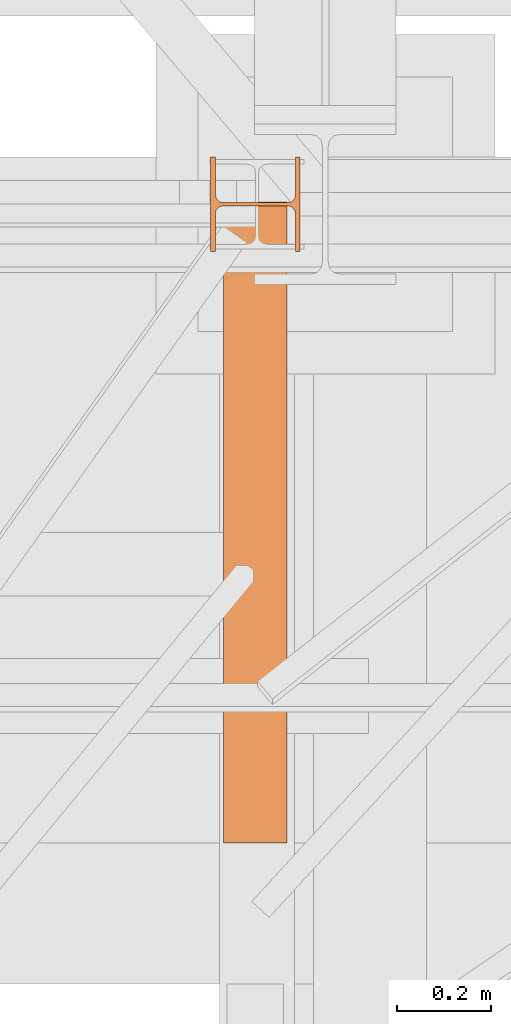
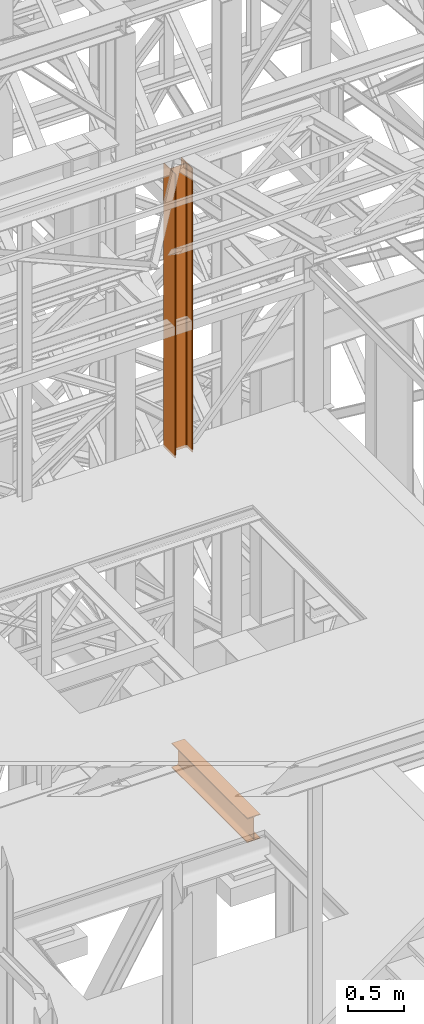
# One storey, part 75 of 208: 2 proxies.
"""IFC2X3 building model written with IfcOpenShell, lengths in millimetres."""

from ifc_helpers import new_model, entity, si_unit, converted_unit, frame, origin, origin_with_axes, place, context, subcontext, project, spatial, faceted_brep, element, save


model = new_model("IFC2X3")

# Units and contexts
model_context = context("Model", 3, precision=1e-05, world=origin())
plan_context = context("Plan", 3, precision=1e-05, world=origin())
body_context = subcontext(model_context, "Body", "Model", "MODEL_VIEW")
ifc_project = project(units=[si_unit("LENGTHUNIT", "METRE", prefix="MILLI"), converted_unit("PLANEANGLEUNIT", "DEGREE", entity("IfcPlaneAngleMeasure", 0.0174532925199433), si_unit("PLANEANGLEUNIT", "RADIAN"), dimensions=[0, 0, 0, 0, 0, 0, 0]), si_unit("AREAUNIT", "SQUARE_METRE"), si_unit("VOLUMEUNIT", "CUBIC_METRE")], contexts=[model_context, plan_context])

# Building, storey
building_placement = place(None, origin())
building = spatial("IfcBuilding", under=ifc_project, at=building_placement, CompositionType="COMPLEX")
storey_placement = place(building_placement, origin_with_axes())
storey = spatial("IfcBuildingStorey", under=building, at=storey_placement, Name="Geschoss", CompositionType="ELEMENT")

# Proxies
proxy_1_placement = place(storey_placement, frame((5249.965071036444, -17362.574391808, 8484.990002086157), z_axis=(0.0, 0.0, 1.0), x_axis=(1.0, 0.0, 0.0)))
element("IfcBuildingElementProxy", 1, at=proxy_1_placement, inside=storey, context=body_context, shape_type="Brep", body=[
    faceted_brep([(190.0100211920199, 0.00999999999839929, 3115.0099922514), (180.0100232781824, 0.00999999999839929, 3115.0099922514), (180.0100158276018, 78.75999940395195, 3115.0099922514), (178.1454707803187, 88.07581143289644, 3115.0099922514), (171.3258277000841, 94.89545311614711, 3115.0099922514), (162.0100166024622, 96.7600014230593, 3115.0099922514), (28.0100058140215, 96.7600014230593, 3115.0099922514), (18.69419471639958, 94.89545311614711, 3115.0099922514), (11.87455163616505, 88.07581143289644, 3115.0099922514), (10.01000658888188, 78.75999940395195, 3115.0099922514), (10.01000658888188, 0.00999999999839929, 3115.0099922514), (0.01000867504444614, 0.00999999999839929, 3115.0099922514), (0.01000867504444614, 200.0100029802306, 3115.0099922514), (10.01000658888188, 200.0100029802306, 3115.0099922514), (10.01000658888188, 121.2600035762771, 3115.0099922514), (11.87455163616505, 111.9441915473326, 3115.0099922514), (18.69419471639958, 105.1245498640819, 3115.0099922514), (28.0100058140215, 103.2600015571697, 3115.0099922514), (162.0100166024622, 103.2600015571697, 3115.0099922514), (171.3258277000841, 105.1245498640819, 3115.0099922514), (178.1454707803187, 111.9441915473326, 3115.0099922514), (180.0100158276018, 121.2600035762771, 3115.0099922514), (180.0100232781824, 200.0100029802306, 3115.0099922514), (190.0100211920199, 200.0100029802306, 3115.0099922514), (190.0100211920199, 200.0100029802306, 3115.0099922514), (190.0100125169756, 200.0100029802306, 0.00999999999839929), (190.0100125169756, 0.00999999999839929, 0.00999999999839929), (190.0100211920199, 0.00999999999839929, 3115.0099922514), (180.0100232781824, 200.0100029802306, 3115.0099922514), (180.0100146031382, 200.0100029802306, 0.00999999999839929), (190.0100125169756, 200.0100029802306, 0.00999999999839929), (190.0100211920199, 200.0100029802306, 3115.0099922514), (180.0100158276018, 121.2600035762771, 3115.0099922514), (180.0100071525576, 121.2600035762771, 0.00999999999839929), (180.0100146031382, 200.0100029802306, 0.00999999999839929), (180.0100232781824, 200.0100029802306, 3115.0099922514), (178.1454707803187, 111.9441915473326, 3115.0099922514), (178.1454621052744, 111.9441915473326, 0.00999999999839929), (180.0100071525576, 121.2600035762771, 0.00999999999839929), (180.0100158276018, 121.2600035762771, 3115.0099922514), (171.3258277000841, 105.1245498640819, 3115.0099922514), (171.3258190250399, 105.1245498640819, 0.00999999999839929), (178.1454621052744, 111.9441915473326, 0.00999999999839929), (178.1454707803187, 111.9441915473326, 3115.0099922514), (162.0100166024622, 103.2600015571697, 3115.0099922514), (162.010007927418, 103.2600015571697, 0.00999999999839929), (171.3258190250399, 105.1245498640819, 0.00999999999839929), (171.3258277000841, 105.1245498640819, 3115.0099922514), (28.0100058140215, 103.2600015571697, 3115.0099922514), (28.00999713897727, 103.2600015571697, 0.00999999999839929), (162.010007927418, 103.2600015571697, 0.00999999999839929), (162.0100166024622, 103.2600015571697, 3115.0099922514), (18.69419471639958, 105.1245498640819, 3115.0099922514), (18.69418604135535, 105.1245498640819, 0.00999999999839929), (28.00999713897727, 103.2600015571697, 0.00999999999839929), (28.0100058140215, 103.2600015571697, 3115.0099922514), (11.87455163616505, 111.9441915473326, 3115.0099922514), (11.87454296112082, 111.9441915473326, 0.00999999999839929), (18.69418604135535, 105.1245498640819, 0.00999999999839929), (18.69419471639958, 105.1245498640819, 3115.0099922514), (10.01000658888188, 121.2600035762771, 3115.0099922514), (10.00999791383765, 121.2600035762771, 0.00999999999839929), (11.87454296112082, 111.9441915473326, 0.00999999999839929), (11.87455163616505, 111.9441915473326, 3115.0099922514), (10.01000658888188, 200.0100029802306, 3115.0099922514), (10.00999791383765, 200.0100029802306, 0.00999999999839929), (10.00999791383765, 121.2600035762771, 0.00999999999839929), (10.01000658888188, 121.2600035762771, 3115.0099922514), (0.01000867504444614, 200.0100029802306, 3115.0099922514), (0.01000000000021828, 200.0100029802306, 0.00999999999839929), (10.00999791383765, 200.0100029802306, 0.00999999999839929), (10.01000658888188, 200.0100029802306, 3115.0099922514), (0.01000867504444614, 0.00999999999839929, 3115.0099922514), (0.01000000000021828, 0.00999999999839929, 0.00999999999839929), (0.01000000000021828, 200.0100029802306, 0.00999999999839929), (0.01000867504444614, 200.0100029802306, 3115.0099922514), (10.01000658888188, 0.00999999999839929, 3115.0099922514), (10.00999791383765, 0.00999999999839929, 0.00999999999839929), (0.01000000000021828, 0.00999999999839929, 0.00999999999839929), (0.01000867504444614, 0.00999999999839929, 3115.0099922514), (10.01000658888188, 78.75999940395195, 3115.0099922514), (10.00999791383765, 78.75999940395195, 0.00999999999839929), (10.00999791383765, 0.00999999999839929, 0.00999999999839929), (10.01000658888188, 0.00999999999839929, 3115.0099922514), (11.87455163616505, 88.07581143289644, 3115.0099922514), (11.87454296112082, 88.07581143289644, 0.00999999999839929), (10.00999791383765, 78.75999940395195, 0.00999999999839929), (10.01000658888188, 78.75999940395195, 3115.0099922514), (18.69419471639958, 94.89545311614711, 3115.0099922514), (18.69418604135535, 94.89545311614711, 0.00999999999839929), (11.87454296112082, 88.07581143289644, 0.00999999999839929), (11.87455163616505, 88.07581143289644, 3115.0099922514), (28.0100058140215, 96.7600014230593, 3115.0099922514), (28.00999713897727, 96.7600014230593, 0.00999999999839929), (18.69418604135535, 94.89545311614711, 0.00999999999839929), (18.69419471639958, 94.89545311614711, 3115.0099922514), (162.0100166024622, 96.7600014230593, 3115.0099922514), (162.010007927418, 96.7600014230593, 0.00999999999839929), (28.00999713897727, 96.7600014230593, 0.00999999999839929), (28.0100058140215, 96.7600014230593, 3115.0099922514), (171.3258277000841, 94.89545311614711, 3115.0099922514), (171.3258190250399, 94.89545311614711, 0.00999999999839929), (162.010007927418, 96.7600014230593, 0.00999999999839929), (162.0100166024622, 96.7600014230593, 3115.0099922514), (178.1454707803187, 88.07581143289644, 3115.0099922514), (178.1454621052744, 88.07581143289644, 0.00999999999839929), (171.3258190250399, 94.89545311614711, 0.00999999999839929), (171.3258277000841, 94.89545311614711, 3115.0099922514), (180.0100158276018, 78.75999940395195, 3115.0099922514), (180.0100071525576, 78.75999940395195, 0.00999999999839929), (178.1454621052744, 88.07581143289644, 0.00999999999839929), (178.1454707803187, 88.07581143289644, 3115.0099922514), (180.0100232781824, 0.00999999999839929, 3115.0099922514), (180.0100146031382, 0.00999999999839929, 0.00999999999839929), (180.0100071525576, 78.75999940395195, 0.00999999999839929), (180.0100158276018, 78.75999940395195, 3115.0099922514), (190.0100211920199, 0.00999999999839929, 3115.0099922514), (190.0100125169756, 0.00999999999839929, 0.00999999999839929), (180.0100146031382, 0.00999999999839929, 0.00999999999839929), (180.0100232781824, 0.00999999999839929, 3115.0099922514), (190.0100125169756, 0.00999999999839929, 0.00999999999839929), (190.0100125169756, 200.0100029802306, 0.00999999999839929), (180.0100146031382, 200.0100029802306, 0.00999999999839929), (180.0100071525576, 121.2600035762771, 0.00999999999839929), (178.1454621052744, 111.9441915473326, 0.00999999999839929), (171.3258190250399, 105.1245498640819, 0.00999999999839929), (162.010007927418, 103.2600015571697, 0.00999999999839929), (28.00999713897727, 103.2600015571697, 0.00999999999839929), (18.69418604135535, 105.1245498640819, 0.00999999999839929), (11.87454296112082, 111.9441915473326, 0.00999999999839929), (10.00999791383765, 121.2600035762771, 0.00999999999839929), (10.00999791383765, 200.0100029802306, 0.00999999999839929), (0.01000000000021828, 200.0100029802306, 0.00999999999839929), (0.01000000000021828, 0.00999999999839929, 0.00999999999839929), (10.00999791383765, 0.00999999999839929, 0.00999999999839929), (10.00999791383765, 78.75999940395195, 0.00999999999839929), (11.87454296112082, 88.07581143289644, 0.00999999999839929), (18.69418604135535, 94.89545311614711, 0.00999999999839929), (28.00999713897727, 96.7600014230593, 0.00999999999839929), (162.010007927418, 96.7600014230593, 0.00999999999839929), (171.3258190250399, 94.89545311614711, 0.00999999999839929), (178.1454621052744, 88.07581143289644, 0.00999999999839929), (180.0100071525576, 78.75999940395195, 0.00999999999839929), (180.0100146031382, 0.00999999999839929, 0.00999999999839929)], [[[0, 1, 2, 3, 4, 5, 6, 7, 8, 9, 10, 11, 12, 13, 14, 15, 16, 17, 18, 19, 20, 21, 22, 23]], [[24, 25, 26, 27]], [[28, 29, 30, 31]], [[32, 33, 34, 35]], [[36, 37, 38, 39]], [[40, 41, 42, 43]], [[44, 45, 46, 47]], [[48, 49, 50, 51]], [[52, 53, 54, 55]], [[56, 57, 58, 59]], [[60, 61, 62, 63]], [[64, 65, 66, 67]], [[68, 69, 70, 71]], [[72, 73, 74, 75]], [[76, 77, 78, 79]], [[80, 81, 82, 83]], [[84, 85, 86, 87]], [[88, 89, 90, 91]], [[92, 93, 94, 95]], [[96, 97, 98, 99]], [[100, 101, 102, 103]], [[104, 105, 106, 107]], [[108, 109, 110, 111]], [[112, 113, 114, 115]], [[116, 117, 118, 119]], [[120, 121, 122, 123, 124, 125, 126, 127, 128, 129, 130, 131, 132, 133, 134, 135, 136, 137, 138, 139, 140, 141, 142, 143]]], orient=[[False], [False], [False], [False], [False], [False], [False], [False], [False], [False], [False], [False], [False], [False], [False], [False], [False], [False], [False], [False], [False], [False], [False], [False], [False], [False]]),
])
proxy_2_placement = place(storey_placement, frame((5276.754968338675, -18618.5743901279, 5014.990005364415), z_axis=(0.0, 0.0, 1.0), x_axis=(1.0, 0.0, 0.0)))
element("IfcBuildingElementProxy", 2, at=proxy_2_placement, inside=storey, context=body_context, shape_type="Brep", body=[
    faceted_brep([(135.0100000000002, 0.01000000000203727, 270.0099999999993), (135.0100000000002, 1361.080528322538, 270.0100000000002), (135.0100000000002, 1361.080528322538, 259.8100001907351), (135.0100000000002, 0.01000000000203727, 259.8100001907351), (135.0100000000002, 0.01000000000203727, 259.8100001907351), (135.0100000000002, 1361.080528322538, 259.8100001907351), (85.8099999523165, 1361.080528322538, 259.810000190736), (85.8099999523165, 0.01000000000203727, 259.8100001907351), (85.8099999523165, 0.01000000000203727, 259.8100001907351), (85.8099999523165, 1361.080528322538, 259.810000190736), (81.17476076017192, 1361.080528322538, 259.0757968253238), (81.17476076017192, 0.01000000000203727, 259.0757968253238), (81.17476076017192, 0.01000000000203727, 259.0757968253238), (81.17476076017192, 1361.080528322538, 259.0757968253238), (76.99323602687218, 1361.080528322538, 256.9452365592924), (76.99323602687218, 0.00999999999839929, 256.9452365592924), (76.99323602687218, 0.00999999999839929, 256.9452365592924), (76.99323602687218, 1361.080528322538, 256.9452365592924), (73.67476358376007, 1361.080528322538, 253.6267641161803), (73.67476358376007, 0.01000000000203727, 253.6267641161803), (73.67476358376007, 0.01000000000203727, 253.6267641161803), (73.67476358376007, 1361.080528322538, 253.6267641161803), (71.5442033177278, 1361.080528322538, 249.4452393828797), (71.5442033177278, 0.01000000000203727, 249.4452393828797), (71.5442033177278, 0.01000000000203727, 249.4452393828797), (71.5442033177278, 1361.080528322538, 249.4452393828797), (70.8099999523165, 1361.080528322538, 244.8100001907351), (70.8099999523165, 0.01000000000203727, 244.8100001907351), (70.8099999523165, 0.01000000000203727, 244.8100001907351), (70.8099999523165, 1361.080528322538, 244.8100001907351), (70.8099999523165, 1361.080528322538, 25.20999980926536), (70.8099999523165, 0.01000000000203727, 25.20999980926536), (70.8099999523165, 0.01000000000203727, 25.20999980926536), (70.8099999523165, 1361.080528322538, 25.20999980926536), (71.5442033177278, 1361.080528322538, 20.57476061712077), (71.5442033177278, 0.01000000000203727, 20.57476061711986), (71.5442033177278, 0.01000000000203727, 20.57476061711986), (71.5442033177278, 1361.080528322538, 20.57476061712077), (73.67476358376007, 1361.080528322538, 16.39323588382013), (73.67476358376007, 0.01000000000203727, 16.39323588382013), (73.67476358376007, 0.01000000000203727, 16.39323588382013), (73.67476358376007, 1361.080528322538, 16.39323588382013), (76.99323602687218, 1361.080528322538, 13.07476344070892), (76.99323602687218, 0.01000000000203727, 13.07476344070892), (76.99323602687218, 0.01000000000203727, 13.07476344070892), (76.99323602687218, 1361.080528322538, 13.07476344070892), (81.17476076017192, 1361.080528322538, 10.94420317467757), (81.17476076017192, 0.01000000000203727, 10.94420317467666), (81.17476076017192, 0.01000000000203727, 10.94420317467666), (81.17476076017192, 1361.080528322538, 10.94420317467757), (85.8099999523165, 1361.080528322538, 10.20999980926536), (85.8099999523165, 0.01000000000203727, 10.20999980926536), (85.8099999523165, 0.01000000000203727, 10.20999980926536), (85.8099999523165, 1361.080528322538, 10.20999980926536), (135.0100000000002, 1361.080528322538, 10.20999980926536), (135.0100000000002, 0.01000000000203727, 10.20999980926536), (135.0100000000002, 0.01000000000203727, 10.20999980926536), (135.0100000000002, 1361.080528322538, 10.20999980926536), (135.0100000000002, 1361.080528322538, 0.01000000000021828), (135.0100000000002, 0.01000000000203727, 0.01000000000112777), (135.0100000000002, 0.01000000000203727, 0.01000000000112777), (135.0100000000002, 1361.080528322538, 0.01000000000021828), (0.01000000000021828, 1361.080528322538, 0.01000000000021828), (0.01000000000021828, 0.01000000000203727, 0.01000000000112777), (0.01000000000021828, 0.01000000000203727, 0.01000000000112777), (0.01000000000021828, 1361.080528322538, 0.01000000000021828), (0.01000000000021828, 1361.080528322538, 10.20999980926626), (0.01000000000021828, 0.01000000000203727, 10.20999980926536), (0.01000000000021828, 0.01000000000203727, 10.20999980926536), (0.01000000000021828, 1361.080528322538, 10.20999980926626), (49.21000004768393, 1361.080528322538, 10.20999980926536), (49.21000004768393, 0.01000000000203727, 10.20999980926536), (49.21000004768393, 0.01000000000203727, 10.20999980926536), (49.21000004768393, 1361.080528322538, 10.20999980926536), (53.09227270367228, 1361.080528322538, 10.72115637176194), (53.09227270367228, 0.01000000000203727, 10.72115637176194), (53.09227270367228, 0.01000000000203727, 10.72115637176194), (53.09227270367228, 1361.080528322538, 10.72115637176194), (56.70997817243006, 1361.080528322538, 12.21965904159242), (56.70997817243006, 0.01000000000203727, 12.21965904159242), (56.70997817243006, 0.01000000000203727, 12.21965904159242), (56.70997817243006, 1361.080528322538, 12.21965904159242), (59.81660176548212, 1361.080528322538, 14.60339809146717), (59.81660176548212, 0.01000000000203727, 14.60339809146717), (59.81660176548212, 0.01000000000203727, 14.60339809146717), (59.81660176548212, 1361.080528322538, 14.60339809146717), (62.20034081535778, 1361.080528322538, 17.71002168452014), (62.20034081535778, 0.01000000000203727, 17.71002168452014), (62.20034081535778, 0.01000000000203727, 17.71002168452014), (62.20034081535778, 1361.080528322538, 17.71002168452014), (63.69884348518826, 1361.080528322538, 21.32772715327792), (63.69884348518826, 0.01000000000203727, 21.32772715327792), (63.69884348518826, 0.01000000000203727, 21.32772715327792), (63.69884348518826, 1361.080528322538, 21.32772715327792), (64.21000004768393, 1361.080528322538, 25.20999980926536), (64.21000004768393, 0.01000000000203727, 25.20999980926536), (64.21000004768393, 0.01000000000203727, 25.20999980926536), (64.21000004768393, 1361.080528322538, 25.20999980926536), (64.21000004768393, 1361.080528322538, 244.8100001907351), (64.21000004768393, 0.01000000000203727, 244.8100001907351), (64.21000004768393, 0.01000000000203727, 244.8100001907351), (64.21000004768393, 1361.080528322538, 244.8100001907351), (63.47579668227263, 1361.080528322538, 249.4452393828797), (63.47579668227263, 0.01000000000203727, 249.4452393828797), (63.47579668227263, 0.01000000000203727, 249.4452393828797), (63.47579668227263, 1361.080528322538, 249.4452393828797), (61.34523641624219, 1361.080528322538, 253.6267641161803), (61.34523641624219, 0.01000000000203727, 253.6267641161803), (61.34523641624219, 0.01000000000203727, 253.6267641161803), (61.34523641624219, 1361.080528322538, 253.6267641161803), (58.02676397313007, 1361.080528322538, 256.9452365592924), (58.02676397313007, 0.01000000000203727, 256.9452365592924), (58.02676397313007, 0.01000000000203727, 256.9452365592924), (58.02676397313007, 1361.080528322538, 256.9452365592924), (53.84523923982852, 1361.080528322538, 259.0757968253238), (53.84523923982852, 0.01000000000203727, 259.0757968253238), (53.84523923982852, 0.01000000000203727, 259.0757968253238), (53.84523923982852, 1361.080528322538, 259.0757968253238), (49.21000004768393, 1361.080528322538, 259.810000190736), (49.21000004768484, 0.01000000000203727, 259.8100001907351), (49.21000004768484, 0.01000000000203727, 259.8100001907351), (49.21000004768393, 1361.080528322538, 259.810000190736), (0.01000000000021828, 1361.080528322538, 259.810000190736), (0.01000000000021828, 0.01000000000203727, 259.8100001907351), (0.01000000000021828, 0.01000000000203727, 259.8100001907351), (0.01000000000021828, 1361.080528322538, 259.810000190736), (0.01000000000021828, 1361.080528322538, 270.0100000000002), (0.01000000000021828, 0.01000000000203727, 270.0100000000002), (0.01000000000021828, 0.01000000000203727, 270.0100000000002), (0.01000000000021828, 1361.080528322538, 270.0100000000002), (135.0100000000002, 1361.080528322538, 270.0100000000002), (135.0100000000002, 0.01000000000203727, 270.0099999999993), (53.84523923982852, 1361.080528322538, 259.0757968253238), (58.02676397313007, 1361.080528322538, 256.9452365592924), (61.34523641624219, 1361.080528322538, 253.6267641161803), (63.47579668227263, 1361.080528322538, 249.4452393828797), (64.21000004768393, 1361.080528322538, 244.8100001907351), (64.21000004768393, 1361.080528322538, 25.20999980926536), (63.69884348518826, 1361.080528322538, 21.32772715327792), (62.20034081535778, 1361.080528322538, 17.71002168452014), (59.81660176548212, 1361.080528322538, 14.60339809146717), (56.70997817243006, 1361.080528322538, 12.21965904159242), (53.09227270367228, 1361.080528322538, 10.72115637176194), (49.21000004768393, 1361.080528322538, 10.20999980926536), (0.01000000000021828, 1361.080528322538, 10.20999980926626), (0.01000000000021828, 1361.080528322538, 0.01000000000021828), (135.0100000000002, 1361.080528322538, 0.01000000000021828), (135.0100000000002, 1361.080528322538, 10.20999980926536), (85.8099999523165, 1361.080528322538, 10.20999980926536), (81.17476076017192, 1361.080528322538, 10.94420317467757), (76.99323602687218, 1361.080528322538, 13.07476344070892), (73.67476358376007, 1361.080528322538, 16.39323588382013), (71.5442033177278, 1361.080528322538, 20.57476061712077), (70.8099999523165, 1361.080528322538, 25.20999980926536), (70.8099999523165, 1361.080528322538, 244.8100001907351), (71.5442033177278, 1361.080528322538, 249.4452393828797), (73.67476358376007, 1361.080528322538, 253.6267641161803), (76.99323602687218, 1361.080528322538, 256.9452365592924), (81.17476076017192, 1361.080528322538, 259.0757968253238), (85.8099999523165, 1361.080528322538, 259.810000190736), (135.0100000000002, 1361.080528322538, 259.8100001907351), (135.0100000000002, 1361.080528322538, 270.0100000000002), (0.01000000000021828, 1361.080528322538, 270.0100000000002), (0.01000000000021828, 1361.080528322538, 259.810000190736), (49.21000004768393, 1361.080528322538, 259.810000190736), (135.0100000000002, 0.01000000000203727, 270.0099999999993), (135.0100000000002, 0.01000000000203727, 259.8100001907351), (85.8099999523165, 0.01000000000203727, 259.8100001907351), (81.17476076017192, 0.01000000000203727, 259.0757968253238), (76.99323602687218, 0.00999999999839929, 256.9452365592924), (73.67476358376007, 0.01000000000203727, 253.6267641161803), (71.5442033177278, 0.01000000000203727, 249.4452393828797), (70.8099999523165, 0.01000000000203727, 244.8100001907351), (70.8099999523165, 0.01000000000203727, 25.20999980926536), (71.5442033177278, 0.01000000000203727, 20.57476061711986), (73.67476358376007, 0.01000000000203727, 16.39323588382013), (76.99323602687218, 0.01000000000203727, 13.07476344070892), (81.17476076017192, 0.01000000000203727, 10.94420317467666), (85.8099999523165, 0.01000000000203727, 10.20999980926536), (135.0100000000002, 0.01000000000203727, 10.20999980926536), (135.0100000000002, 0.01000000000203727, 0.01000000000112777), (0.01000000000021828, 0.01000000000203727, 0.01000000000112777), (0.01000000000021828, 0.01000000000203727, 10.20999980926536), (49.21000004768393, 0.01000000000203727, 10.20999980926536), (53.09227270367228, 0.01000000000203727, 10.72115637176194), (56.70997817243006, 0.01000000000203727, 12.21965904159242), (59.81660176548212, 0.01000000000203727, 14.60339809146717), (62.20034081535778, 0.01000000000203727, 17.71002168452014), (63.69884348518826, 0.01000000000203727, 21.32772715327792), (64.21000004768393, 0.01000000000203727, 25.20999980926536), (64.21000004768393, 0.01000000000203727, 244.8100001907351), (63.47579668227263, 0.01000000000203727, 249.4452393828797), (61.34523641624219, 0.01000000000203727, 253.6267641161803), (58.02676397313007, 0.01000000000203727, 256.9452365592924), (53.84523923982852, 0.01000000000203727, 259.0757968253238), (49.21000004768484, 0.01000000000203727, 259.8100001907351), (0.01000000000021828, 0.01000000000203727, 259.8100001907351), (0.01000000000021828, 0.01000000000203727, 270.0100000000002)], [[[0, 1, 2, 3]], [[4, 5, 6, 7]], [[8, 9, 10, 11]], [[12, 13, 14, 15]], [[16, 17, 18, 19]], [[20, 21, 22, 23]], [[24, 25, 26, 27]], [[28, 29, 30, 31]], [[32, 33, 34, 35]], [[36, 37, 38, 39]], [[40, 41, 42, 43]], [[44, 45, 46, 47]], [[48, 49, 50, 51]], [[52, 53, 54, 55]], [[56, 57, 58, 59]], [[60, 61, 62, 63]], [[64, 65, 66, 67]], [[68, 69, 70, 71]], [[72, 73, 74, 75]], [[76, 77, 78, 79]], [[80, 81, 82, 83]], [[84, 85, 86, 87]], [[88, 89, 90, 91]], [[92, 93, 94, 95]], [[96, 97, 98, 99]], [[100, 101, 102, 103]], [[104, 105, 106, 107]], [[108, 109, 110, 111]], [[112, 113, 114, 115]], [[116, 117, 118, 119]], [[120, 121, 122, 123]], [[124, 125, 126, 127]], [[128, 129, 130, 131]], [[132, 133, 134, 135, 136, 137, 138, 139, 140, 141, 142, 143, 144, 145, 146, 147, 148, 149, 150, 151, 152, 153, 154, 155, 156, 157, 158, 159, 160, 161, 162, 163, 164]], [[165, 166, 167, 168, 169, 170, 171, 172, 173, 174, 175, 176, 177, 178, 179, 180, 181, 182, 183, 184, 185, 186, 187, 188, 189, 190, 191, 192, 193, 194, 195, 196, 197]]], orient=[[False], [False], [False], [False], [False], [False], [False], [False], [False], [False], [False], [False], [False], [False], [False], [False], [False], [False], [False], [False], [False], [False], [False], [False], [False], [False], [False], [False], [False], [False], [False], [False], [False], [False], [False]]),
])

save(model, "model.ifc")
